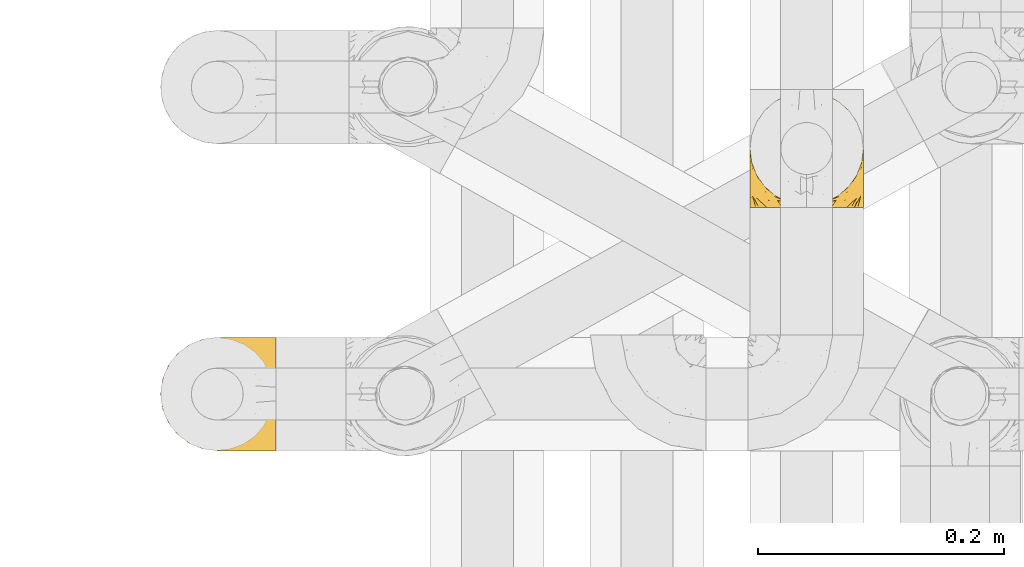
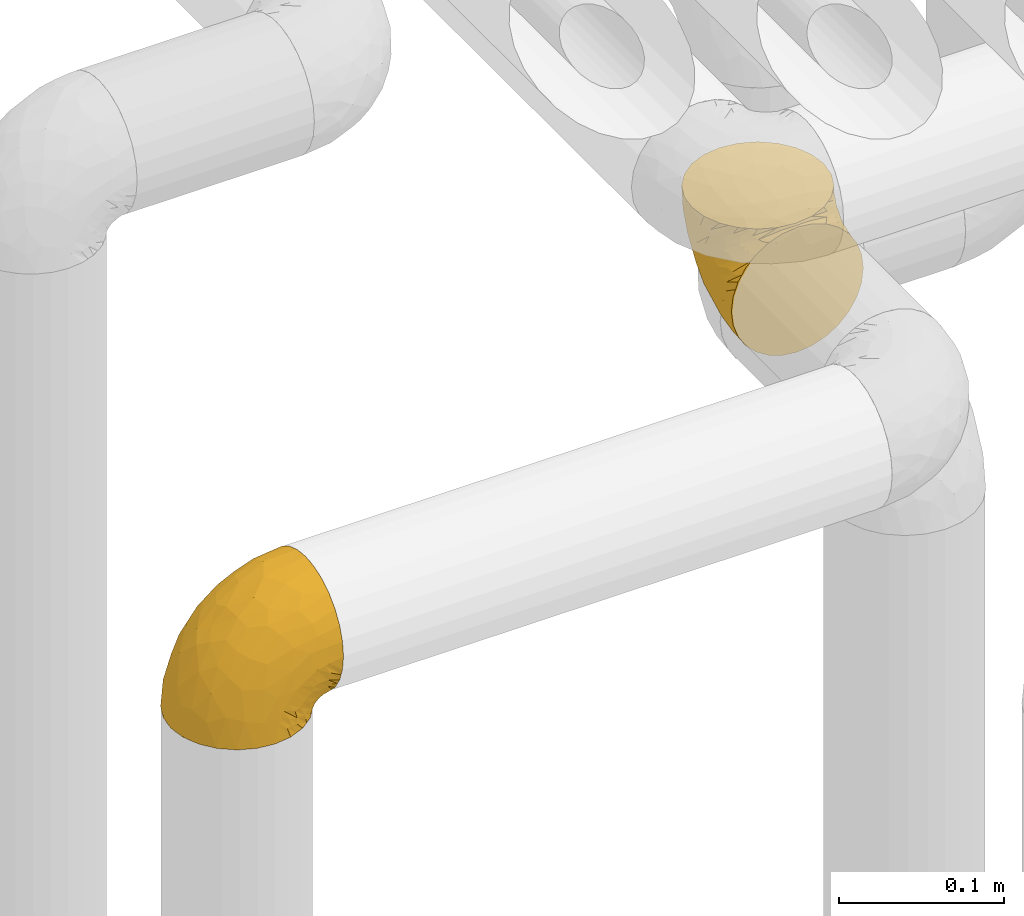
# One storey, part 172 of 827: 2 coverings.
"""IFC2X3 building model written with IfcOpenShell, lengths in millimetres."""

from ifc_helpers import new_model, entity, si_unit, converted_unit, derived_unit, direction, frame, origin, place, context, subcontext, project, spatial, faceted_brep, element, save


model = new_model("IFC2X3")

# Units and contexts
model_context = context("Model", 3, precision=0.01, world=origin(), true_north=direction((6.12303176911189e-17, 1.0)))
body_context = subcontext(model_context, "Body", "Model", "MODEL_VIEW")
ifc_project = project(units=[si_unit("LENGTHUNIT", "METRE", prefix="MILLI"), si_unit("AREAUNIT", "SQUARE_METRE"), si_unit("VOLUMEUNIT", "CUBIC_METRE"), converted_unit("PLANEANGLEUNIT", "DEGREE", entity("IfcRatioMeasure", 0.0174532925199433), si_unit("PLANEANGLEUNIT", "RADIAN"), dimensions=[0, 0, 0, 0, 0, 0, 0]), si_unit("MASSUNIT", "GRAM", prefix="KILO"), derived_unit("MASSDENSITYUNIT", [(si_unit("MASSUNIT", "GRAM", prefix="KILO"), 1), (si_unit("LENGTHUNIT", "METRE"), -3)]), derived_unit("MOMENTOFINERTIAUNIT", [(si_unit("LENGTHUNIT", "METRE"), 4)]), si_unit("TIMEUNIT", "SECOND"), si_unit("FREQUENCYUNIT", "HERTZ"), si_unit("THERMODYNAMICTEMPERATUREUNIT", "DEGREE_CELSIUS"), derived_unit("THERMALTRANSMITTANCEUNIT", [(si_unit("MASSUNIT", "GRAM", prefix="KILO"), 1), (si_unit("THERMODYNAMICTEMPERATUREUNIT", "KELVIN"), -1), (si_unit("TIMEUNIT", "SECOND"), -3)]), derived_unit("VOLUMETRICFLOWRATEUNIT", [(si_unit("LENGTHUNIT", "METRE"), 3), (si_unit("TIMEUNIT", "SECOND"), -1)]), derived_unit("MASSFLOWRATEUNIT", [(si_unit("MASSUNIT", "GRAM", prefix="KILO"), 1), (si_unit("TIMEUNIT", "SECOND"), -1)]), derived_unit("ROTATIONALFREQUENCYUNIT", [(si_unit("TIMEUNIT", "SECOND"), -1)]), si_unit("ELECTRICCURRENTUNIT", "AMPERE"), si_unit("ELECTRICVOLTAGEUNIT", "VOLT"), si_unit("POWERUNIT", "WATT"), si_unit("FORCEUNIT", "NEWTON", prefix="KILO"), si_unit("ILLUMINANCEUNIT", "LUX"), si_unit("LUMINOUSFLUXUNIT", "LUMEN"), si_unit("LUMINOUSINTENSITYUNIT", "CANDELA"), derived_unit("USERDEFINED", [(si_unit("MASSUNIT", "GRAM", prefix="KILO"), -1), (si_unit("LENGTHUNIT", "METRE"), -2), (si_unit("TIMEUNIT", "SECOND"), 3), (si_unit("LUMINOUSFLUXUNIT", "LUMEN"), 1)]), derived_unit("LINEARVELOCITYUNIT", [(si_unit("LENGTHUNIT", "METRE"), 1), (si_unit("TIMEUNIT", "SECOND"), -1)]), si_unit("PRESSUREUNIT", "PASCAL"), derived_unit("USERDEFINED", [(si_unit("LENGTHUNIT", "METRE"), -2), (si_unit("MASSUNIT", "GRAM", prefix="KILO"), 1), (si_unit("TIMEUNIT", "SECOND"), -2)]), derived_unit("LINEARFORCEUNIT", [(si_unit("MASSUNIT", "GRAM", prefix="KILO"), 1), (si_unit("LENGTHUNIT", "METRE"), 1), (si_unit("TIMEUNIT", "SECOND"), -2), (si_unit("LENGTHUNIT", "METRE"), -1)]), derived_unit("PLANARFORCEUNIT", [(si_unit("MASSUNIT", "GRAM", prefix="KILO"), 1), (si_unit("LENGTHUNIT", "METRE"), 1), (si_unit("TIMEUNIT", "SECOND"), -2), (si_unit("LENGTHUNIT", "METRE"), -2)])], contexts=[model_context])

# Site, building, storey
site_placement = place(None, origin())
site = spatial("IfcSite", under=ifc_project, at=site_placement, CompositionType="ELEMENT")
building_placement = place(site_placement, origin())
building = spatial("IfcBuilding", under=site, at=building_placement, CompositionType="ELEMENT")
storey_placement = place(building_placement, frame((0.0, 0.0, 28200.0)))
storey = spatial("IfcBuildingStorey", under=building, at=storey_placement, Name="08", CompositionType="ELEMENT", Elevation=28200.0)

# Coverings
covering_1_placement = place(storey_placement, frame((35552.3, 12906.58, 2751.81)))
element("IfcCovering", 1, at=covering_1_placement, inside=storey, Name=":ADSK_", ObjectType=":ADSK_", PredefinedType="INSULATION", context=body_context, shape_type="Brep", body=[
    faceted_brep([(11.68, 1.6, 18.98), (19.0, 1.6, 11.67), (27.76, 1.6, 6.17), (37.52, 1.6, 2.75), (47.8, 1.6, 1.6), (58.08, 1.6, 2.75), (67.85, 1.6, 6.17), (76.61, 1.6, 11.68), (83.92, 1.6, 19.0), (89.42, 1.6, 27.76), (92.84, 1.6, 37.52), (94.0, 1.6, 47.8), (93.53, 1.6, 51.94), (93.18, 1.6, 55.01), (92.84, 1.6, 58.08), (91.13, 1.6, 62.96), (89.42, 1.6, 67.85), (86.66, 1.6, 72.23), (83.91, 1.6, 76.61), (80.25, 1.6, 80.26), (76.59, 1.6, 83.92), (67.83, 1.6, 89.42), (62.95, 1.6, 91.13), (58.07, 1.6, 92.84), (47.8, 1.6, 94.0), (37.51, 1.6, 92.84), (32.63, 1.6, 91.13), (27.74, 1.6, 89.42), (18.98, 1.6, 83.91), (15.33, 1.6, 80.25), (11.67, 1.6, 76.59), (8.92, 1.6, 72.21), (6.17, 1.6, 67.83), (4.46, 1.6, 62.95), (2.75, 1.6, 58.07), (2.41, 1.6, 55.0), (2.06, 1.6, 51.94), (1.6, 1.6, 47.8), (2.75, 1.6, 37.51), (6.17, 1.6, 27.74), (47.8, 3.4, 95.8), (59.75, 4.97, 95.8), (70.9, 9.58, 95.8), (75.68, 13.26, 95.8), (80.46, 16.93, 95.8), (84.13, 21.71, 95.8), (87.81, 26.5, 95.8), (90.11, 32.07, 95.8), (92.42, 37.64, 95.8), (92.9, 41.25, 95.8), (93.17, 43.34, 95.8), (93.45, 45.42, 95.8), (94.0, 49.6, 95.8), (92.42, 61.55, 95.8), (87.81, 72.7, 95.8), (80.46, 82.26, 95.8), (70.9, 89.61, 95.8), (59.75, 94.22, 95.8), (47.8, 95.8, 95.8), (35.84, 94.22, 95.8), (24.7, 89.61, 95.8), (15.13, 82.26, 95.8), (7.78, 72.7, 95.8), (3.17, 61.55, 95.8), (1.6, 49.6, 95.8), (2.14, 45.42, 95.8), (2.69, 41.25, 95.8), (3.17, 37.64, 95.8), (5.48, 32.07, 95.8), (7.78, 26.5, 95.8), (11.46, 21.71, 95.8), (15.13, 16.93, 95.8), (19.91, 13.26, 95.8), (24.7, 9.58, 95.8), (35.84, 4.97, 95.8), (23.61, 81.55, 60.58), (31.99, 90.4, 74.11), (35.87, 83.0, 51.59), (47.8, 91.18, 66.69), (40.43, 93.13, 76.19), (47.8, 94.0, 84.43), (31.83, 66.19, 31.2), (23.37, 70.92, 42.88), (21.41, 85.95, 79.41), (3.07, 49.74, 60.7), (1.6, 35.54, 61.85), (1.6, 38.14, 65.75), (1.6, 40.74, 69.64), (1.6, 43.34, 73.53), (1.6, 45.94, 77.43), (13.45, 77.59, 74.59), (15.25, 71.17, 54.72), (8.07, 65.81, 64.18), (16.0, 59.03, 37.94), (17.34, 45.85, 25.89), (10.58, 45.79, 34.73), (5.34, 41.42, 42.89), (2.39, 34.51, 49.83), (8.36, 56.04, 48.58), (10.04, 15.15, 22.41), (2.59, 56.51, 78.69), (6.28, 68.39, 81.64), (34.28, 23.33, 6.22), (38.73, 42.86, 12.11), (27.25, 39.42, 14.81), (29.88, 53.58, 21.61), (38.6, 59.17, 22.41), (23.44, 59.06, 30.12), (25.25, 22.63, 10.01), (17.23, 20.55, 15.36), (47.8, 12.96, 3.39), (47.8, 56.96, 19.59), (47.8, 67.38, 30.01), (2.53, 18.72, 41.19), (1.6, 5.33, 48.54), (1.6, 9.07, 49.28), (1.6, 11.79, 49.82), (1.6, 14.51, 50.37), (1.6, 17.24, 50.91), (1.6, 19.96, 51.45), (5.71, 21.03, 31.61), (1.6, 46.48, 80.15), (1.6, 47.03, 82.88), (1.6, 47.57, 85.6), (1.6, 48.11, 88.32), (1.6, 48.48, 90.19), (1.6, 48.85, 92.06), (47.8, 30.7, 6.21), (1.6, 23.86, 54.05), (1.6, 27.75, 56.65), (1.6, 31.64, 59.25), (11.89, 31.26, 24.66), (47.8, 77.8, 40.43), (39.69, 72.75, 35.17), (47.8, 43.83, 12.9), (47.8, 84.49, 53.56), (13.84, 14.58, 85.34), (9.16, 16.17, 78.44), (15.79, 10.82, 84.37), (25.75, 4.64, 89.05), (16.09, 7.71, 82.76), (7.51, 25.13, 86.31), (3.99, 32.66, 83.73), (2.66, 34.94, 77.31), (3.16, 36.76, 87.78), (2.35, 40.48, 87.91), (2.23, 39.25, 81.29), (38.35, 3.69, 93.97), (6.18, 13.99, 70.76), (2.7, 21.85, 63.67), (2.93, 17.93, 62.62), (16.01, 15.11, 90.64), (9.08, 21.14, 84.08), (11.68, 7.21, 77.45), (6.83, 9.47, 70.34), (21.65, 10.45, 91.35), (4.65, 32.27, 88.72), (3.65, 25.68, 71.28), (3.61, 22.18, 68.09), (12.8, 18.79, 91.07), (2.43, 10.12, 57.47), (3.7, 11.29, 62.99), (47.8, 2.87, 94.52), (3.37, 31.16, 76.47), (9.3, 12.7, 76.28), (7.03, 6.31, 69.96), (7.87, 25.62, 89.86), (7.26, 21.18, 78.94), (3.41, 28.81, 73.51), (23.81, 7.45, 89.62), (86.5, 21.14, 84.09), (88.08, 25.13, 86.3), (82.79, 18.79, 91.06), (94.0, 48.85, 92.06), (94.0, 47.03, 82.88), (94.0, 47.57, 85.6), (94.0, 48.11, 88.32), (57.24, 3.69, 93.97), (71.76, 7.44, 89.63), (94.0, 14.51, 50.37), (94.0, 11.79, 49.82), (94.0, 5.33, 48.54), (94.0, 9.07, 49.28), (79.49, 7.71, 82.77), (88.75, 9.47, 70.36), (92.93, 34.94, 77.31), (92.22, 31.16, 76.47), (94.0, 40.74, 69.64), (94.0, 38.14, 65.75), (92.43, 36.76, 87.78), (93.24, 40.48, 87.91), (69.82, 4.63, 89.06), (79.57, 15.11, 90.65), (81.74, 14.58, 85.35), (94.0, 43.34, 73.53), (94.0, 45.94, 77.43), (93.36, 39.25, 81.29), (83.9, 7.21, 77.46), (86.28, 12.69, 76.29), (93.16, 10.14, 57.47), (92.88, 21.81, 63.71), (91.98, 22.19, 68.11), (89.41, 14.0, 70.77), (91.93, 25.69, 71.31), (86.42, 16.17, 78.46), (88.82, 6.66, 69.52), (92.66, 17.92, 62.64), (73.93, 10.45, 91.35), (94.0, 31.64, 59.25), (79.5, 10.64, 84.6), (91.89, 11.31, 62.98), (94.0, 19.96, 51.45), (94.0, 23.86, 54.05), (94.0, 27.75, 56.65), (91.6, 32.66, 83.73), (94.0, 46.48, 80.15), (90.94, 32.27, 88.72), (94.0, 35.54, 61.85), (92.16, 28.77, 73.56), (88.32, 21.17, 78.96), (86.13, 23.36, 91.36), (94.0, 17.24, 50.91), (93.2, 47.58, 62.87), (55.16, 93.13, 76.19), (82.02, 77.44, 73.57), (84.29, 66.78, 56.07), (76.94, 71.68, 49.77), (68.33, 74.96, 44.73), (71.98, 81.55, 60.58), (92.52, 36.7, 47.64), (92.9, 56.9, 78.32), (59.72, 83.0, 51.59), (63.6, 90.4, 74.11), (88.89, 67.83, 76.04), (74.18, 85.95, 79.41), (68.35, 39.41, 14.82), (61.33, 23.33, 6.22), (56.86, 42.87, 12.12), (68.62, 53.92, 23.51), (63.76, 66.19, 31.2), (72.19, 64.12, 34.96), (88.69, 33.13, 33.86), (92.19, 23.1, 38.94), (89.75, 16.98, 30.23), (59.86, 55.72, 20.67), (55.9, 72.75, 35.17), (77.99, 23.77, 15.85), (85.21, 18.41, 22.59), (74.99, 43.7, 21.56), (90.23, 54.53, 55.94), (70.75, 17.73, 9.19), (81.72, 38.98, 25.79), (86.53, 50.28, 41.16), (79.6, 59.02, 37.95)], [[[0, 1, 2, 3, 4, 5, 6, 7, 8, 9, 10, 11, 12, 13, 14, 15, 16, 17, 18, 19, 20, 21, 22, 23, 24, 25, 26, 27, 28, 29, 30, 31, 32, 33, 34, 35, 36, 37, 38, 39]], [[40, 41, 42, 43, 44, 45, 46, 47, 48, 49, 50, 51, 52, 53, 54, 55, 56, 57, 58, 59, 60, 61, 62, 63, 64, 65, 66, 67, 68, 69, 70, 71, 72, 73, 74]], [[75, 76, 77]], [[78, 79, 80]], [[77, 81, 82]], [[76, 75, 83]], [[84, 85, 86, 87, 88, 89]], [[90, 91, 92]], [[76, 60, 59]], [[93, 94, 95]], [[90, 62, 61]], [[83, 61, 60]], [[96, 97, 84]], [[98, 93, 95]], [[0, 39, 99]], [[100, 84, 89]], [[62, 101, 63]], [[2, 102, 3]], [[92, 84, 100]], [[103, 102, 104]], [[103, 105, 106]], [[93, 107, 94]], [[1, 108, 2]], [[92, 101, 90]], [[108, 1, 109]], [[102, 110, 3]], [[93, 82, 107]], [[102, 108, 104]], [[111, 106, 112]], [[109, 0, 99]], [[113, 37, 114, 115, 116, 117, 118, 119]], [[120, 38, 113]], [[100, 89, 121, 122, 123, 124, 125, 126, 64]], [[127, 102, 103]], [[97, 119, 128, 129, 130, 85]], [[99, 120, 131]], [[132, 133, 77]], [[59, 80, 79]], [[1, 0, 109]], [[98, 84, 92]], [[94, 109, 131]], [[120, 39, 38]], [[93, 91, 82]], [[104, 94, 105]], [[97, 113, 119]], [[95, 120, 96]], [[83, 90, 61]], [[91, 93, 98]], [[64, 63, 100]], [[100, 63, 101]], [[77, 76, 79]], [[133, 106, 81]], [[84, 97, 85]], [[113, 96, 120]], [[113, 97, 96]], [[37, 113, 38]], [[110, 102, 127]], [[110, 4, 3]], [[103, 111, 134, 127]], [[90, 75, 91]], [[82, 81, 107]], [[91, 75, 82]], [[77, 82, 75]], [[76, 83, 60]], [[90, 83, 75]], [[105, 107, 81]], [[94, 131, 95]], [[105, 94, 107]], [[109, 94, 104]], [[120, 95, 131]], [[98, 95, 96]], [[84, 98, 96]], [[98, 92, 91]], [[106, 105, 81]], [[103, 104, 105]], [[133, 132, 112]], [[103, 106, 111]], [[77, 78, 135, 132]], [[106, 133, 112]], [[77, 133, 81]], [[120, 99, 39]], [[109, 99, 131]], [[59, 58, 80]], [[59, 79, 76]], [[90, 101, 62]], [[100, 101, 92]], [[2, 108, 102]], [[109, 104, 108]], [[78, 77, 79]], [[136, 137, 138]], [[27, 139, 140]], [[141, 142, 143]], [[144, 145, 121]], [[146, 89, 88]], [[147, 139, 25]], [[148, 149, 150]], [[136, 151, 152]], [[147, 40, 74]], [[24, 147, 25]], [[153, 148, 154]], [[33, 116, 34]], [[73, 151, 155]], [[114, 37, 36, 35, 34, 116, 115]], [[146, 156, 144]], [[157, 85, 130]], [[158, 149, 148]], [[151, 159, 152]], [[117, 33, 160]], [[29, 153, 154]], [[155, 74, 73]], [[161, 128, 119]], [[66, 65, 64, 126, 125, 124, 123, 122, 67]], [[162, 147, 24]], [[27, 140, 28]], [[149, 129, 150]], [[139, 27, 26, 25]], [[68, 144, 69]], [[129, 128, 150]], [[163, 87, 86]], [[130, 129, 149]], [[122, 145, 67]], [[153, 164, 148]], [[161, 119, 160]], [[165, 30, 154]], [[150, 154, 148]], [[128, 161, 150]], [[30, 165, 31]], [[145, 144, 68]], [[89, 146, 144]], [[87, 163, 143]], [[166, 156, 142]], [[88, 87, 143]], [[161, 154, 150]], [[154, 30, 29]], [[29, 28, 153]], [[28, 140, 153]], [[164, 153, 140]], [[140, 137, 164]], [[158, 148, 164]], [[157, 130, 158]], [[164, 137, 158]], [[158, 137, 157]], [[167, 137, 136]], [[168, 85, 157]], [[152, 168, 167]], [[167, 168, 157]], [[163, 152, 141]], [[151, 73, 72]], [[159, 72, 71]], [[88, 142, 146]], [[144, 156, 69]], [[146, 142, 156]], [[70, 166, 71]], [[142, 141, 166]], [[70, 69, 156]], [[141, 159, 71]], [[167, 136, 152]], [[138, 137, 140]], [[155, 136, 169]], [[136, 155, 151]], [[74, 155, 169]], [[152, 159, 141]], [[151, 72, 159]], [[168, 152, 163]], [[137, 167, 157]], [[163, 86, 168]], [[85, 168, 86]], [[116, 33, 117]], [[130, 149, 158]], [[67, 145, 68]], [[121, 89, 144]], [[145, 122, 121]], [[40, 147, 162]], [[169, 147, 74]], [[160, 33, 32]], [[161, 160, 32]], [[160, 119, 118, 117]], [[139, 147, 169]], [[139, 169, 138]], [[161, 32, 31]], [[141, 143, 163]], [[88, 143, 142]], [[71, 166, 141]], [[156, 166, 70]], [[139, 138, 140]], [[169, 136, 138]], [[154, 161, 165]], [[161, 31, 165]], [[170, 171, 172]], [[173, 52, 51, 50, 49, 48, 174, 175, 176]], [[177, 178, 41]], [[179, 15, 180]], [[12, 11, 181, 182, 180, 14, 13]], [[183, 21, 20]], [[19, 18, 184]], [[185, 186, 187]], [[186, 188, 187]], [[43, 172, 44]], [[189, 190, 47]], [[23, 22, 21, 191]], [[170, 192, 193]], [[40, 162, 177]], [[194, 195, 196]], [[24, 23, 177]], [[197, 198, 183]], [[199, 15, 179]], [[47, 46, 189]], [[200, 201, 202]], [[201, 203, 204]], [[205, 206, 184]], [[207, 41, 178]], [[16, 15, 199]], [[14, 180, 15]], [[202, 201, 198]], [[208, 201, 200]], [[162, 24, 177]], [[48, 47, 190]], [[196, 195, 189]], [[197, 184, 202]], [[204, 193, 209]], [[210, 211, 212]], [[206, 212, 213]], [[205, 17, 210]], [[184, 206, 202]], [[210, 212, 206]], [[185, 194, 214]], [[189, 215, 190]], [[216, 45, 214]], [[186, 171, 170]], [[189, 216, 196]], [[197, 20, 19]], [[194, 185, 187]], [[197, 183, 20]], [[184, 197, 19]], [[197, 202, 198]], [[206, 200, 202]], [[204, 183, 198]], [[201, 208, 203]], [[203, 208, 217]], [[204, 198, 201]], [[217, 188, 218]], [[193, 219, 170]], [[171, 186, 185]], [[170, 218, 186]], [[170, 219, 218]], [[42, 207, 192]], [[171, 220, 172]], [[216, 189, 46]], [[214, 194, 196]], [[44, 220, 45]], [[214, 196, 216]], [[216, 46, 45]], [[214, 45, 220]], [[192, 43, 42]], [[204, 203, 219]], [[207, 193, 192]], [[209, 193, 178]], [[41, 207, 42]], [[193, 207, 178]], [[43, 192, 172]], [[170, 172, 192]], [[204, 219, 193]], [[219, 203, 218]], [[217, 218, 203]], [[188, 186, 218]], [[206, 213, 200]], [[208, 200, 213]], [[199, 210, 16]], [[215, 189, 195]], [[215, 174, 190]], [[174, 48, 190]], [[199, 179, 221, 211]], [[210, 199, 211]], [[23, 191, 177]], [[40, 177, 41]], [[183, 209, 191]], [[183, 191, 21]], [[191, 178, 177]], [[205, 18, 17]], [[17, 16, 210]], [[171, 185, 214]], [[172, 220, 44]], [[214, 220, 171]], [[191, 209, 178]], [[204, 209, 183]], [[206, 205, 210]], [[18, 205, 184]], [[222, 195, 194, 187, 188, 217]], [[57, 223, 80]], [[224, 225, 226]], [[226, 227, 228]], [[229, 217, 208, 213, 212, 211]], [[230, 52, 173, 176, 175, 174, 215, 195]], [[231, 232, 228]], [[231, 78, 223]], [[223, 57, 232]], [[224, 233, 225]], [[233, 54, 53]], [[234, 232, 56]], [[56, 55, 234]], [[234, 224, 228]], [[235, 236, 237]], [[224, 55, 54]], [[238, 239, 240]], [[52, 230, 53]], [[241, 242, 243]], [[239, 244, 245]], [[11, 10, 242]], [[236, 6, 5]], [[7, 246, 8]], [[8, 247, 9]], [[238, 248, 235]], [[222, 229, 249]], [[242, 211, 221, 179, 180, 182, 181, 11]], [[233, 53, 230]], [[111, 112, 244]], [[250, 6, 236]], [[247, 251, 241]], [[6, 250, 7]], [[127, 236, 110]], [[249, 229, 252]], [[247, 8, 246]], [[235, 246, 250]], [[236, 5, 110]], [[235, 244, 238]], [[237, 236, 127]], [[243, 9, 247]], [[252, 229, 241]], [[56, 232, 57]], [[222, 230, 195]], [[225, 249, 252]], [[249, 233, 230]], [[54, 233, 224]], [[231, 228, 227]], [[245, 132, 231]], [[249, 225, 233]], [[226, 225, 253]], [[235, 250, 236]], [[246, 7, 250]], [[251, 247, 246]], [[243, 247, 241]], [[248, 246, 235]], [[252, 251, 253]], [[229, 222, 217]], [[230, 222, 249]], [[5, 4, 110]], [[237, 127, 134, 111]], [[238, 244, 239]], [[224, 234, 55]], [[232, 234, 228]], [[242, 241, 229]], [[10, 9, 243]], [[211, 242, 229]], [[10, 243, 242]], [[80, 223, 78]], [[80, 58, 57]], [[231, 223, 232]], [[227, 240, 239]], [[224, 226, 228]], [[240, 226, 253]], [[227, 239, 245]], [[226, 240, 227]], [[251, 248, 253]], [[240, 253, 248]], [[244, 235, 237]], [[237, 111, 244]], [[132, 245, 112]], [[112, 245, 244]], [[135, 78, 231, 132]], [[227, 245, 231]], [[248, 238, 240]], [[246, 248, 251]], [[251, 252, 241]], [[225, 252, 253]]]),
])
covering_2_placement = place(storey_placement, frame((35072.24, 12708.4, 2750.01)))
element("IfcCovering", 2, at=covering_2_placement, inside=storey, Name=":ADSK_", ObjectType=":ADSK_", PredefinedType="INSULATION", context=body_context, shape_type="Brep", body=[
    faceted_brep([(95.8, 94.0, 49.6), (95.8, 92.84, 59.88), (95.8, 89.42, 69.65), (95.8, 83.91, 78.41), (95.8, 76.59, 85.72), (95.8, 67.83, 91.22), (95.8, 58.07, 94.64), (95.8, 47.8, 95.8), (95.79, 37.51, 94.64), (95.79, 27.74, 91.22), (95.79, 18.98, 85.71), (95.79, 11.67, 78.39), (95.79, 6.17, 69.63), (95.79, 2.75, 59.87), (95.79, 1.6, 49.6), (95.79, 2.06, 45.45), (95.79, 2.41, 42.38), (95.79, 2.75, 39.31), (95.79, 4.46, 34.43), (95.79, 6.17, 29.54), (95.79, 8.93, 25.16), (95.79, 11.68, 20.78), (95.79, 15.34, 17.13), (95.79, 19.0, 13.47), (95.79, 27.76, 7.97), (95.79, 32.64, 6.26), (95.79, 37.52, 4.55), (95.8, 47.8, 3.4), (95.8, 58.08, 4.55), (95.8, 62.96, 6.26), (95.8, 67.85, 7.97), (95.8, 76.61, 13.48), (95.8, 80.26, 17.14), (95.8, 83.92, 20.8), (95.8, 86.67, 25.18), (95.8, 89.42, 29.56), (95.8, 91.13, 34.44), (95.8, 92.84, 39.32), (95.8, 93.18, 42.39), (95.8, 93.53, 45.45), (94.0, 47.8, 1.6), (92.42, 35.84, 1.6), (87.8, 24.7, 1.6), (84.13, 19.91, 1.6), (80.46, 15.13, 1.6), (75.68, 11.46, 1.6), (70.89, 7.79, 1.6), (65.32, 5.48, 1.6), (59.75, 3.17, 1.6), (56.14, 2.7, 1.6), (54.05, 2.42, 1.6), (51.97, 2.15, 1.6), (47.79, 1.6, 1.6), (35.83, 3.17, 1.6), (24.69, 7.79, 1.6), (15.12, 15.13, 1.6), (7.78, 24.7, 1.6), (3.17, 35.84, 1.6), (1.6, 47.8, 1.6), (3.17, 59.76, 1.6), (7.79, 70.9, 1.6), (15.13, 80.47, 1.6), (24.7, 87.81, 1.6), (35.84, 92.43, 1.6), (47.8, 94.0, 1.6), (51.97, 93.45, 1.6), (56.14, 92.9, 1.6), (59.76, 92.42, 1.6), (65.33, 90.12, 1.6), (70.9, 87.81, 1.6), (75.68, 84.14, 1.6), (80.47, 80.46, 1.6), (84.14, 75.68, 1.6), (87.81, 70.9, 1.6), (92.42, 59.75, 1.6), (15.84, 71.99, 36.81), (6.99, 63.61, 23.28), (14.39, 59.73, 45.8), (6.21, 47.8, 30.7), (4.26, 55.17, 21.2), (3.39, 47.8, 12.96), (31.2, 63.76, 66.19), (26.47, 72.23, 54.51), (11.45, 74.18, 17.98), (47.66, 92.53, 36.69), (61.86, 94.0, 35.54), (59.26, 94.0, 31.64), (56.65, 94.0, 27.75), (54.05, 94.0, 23.86), (51.45, 94.0, 19.96), (19.8, 82.15, 22.8), (26.22, 80.34, 42.67), (31.58, 87.53, 33.21), (38.36, 79.59, 59.45), (51.54, 78.26, 71.5), (51.6, 85.01, 62.66), (55.97, 90.25, 54.5), (62.88, 93.2, 47.57), (41.35, 87.23, 48.81), (82.25, 85.55, 74.98), (40.88, 93.01, 18.7), (29.01, 89.31, 15.75), (74.06, 61.32, 91.17), (54.53, 56.86, 85.28), (57.98, 68.34, 82.58), (43.81, 65.71, 75.78), (38.22, 57.0, 74.98), (38.34, 72.15, 67.27), (74.76, 70.34, 87.38), (76.85, 78.36, 82.04), (84.43, 47.8, 94.0), (40.43, 47.8, 77.8), (30.01, 47.8, 67.38), (78.68, 93.06, 56.2), (92.06, 94.0, 48.85), (88.33, 94.0, 48.11), (85.6, 94.0, 47.57), (82.88, 94.0, 47.03), (80.15, 94.0, 46.48), (77.43, 94.0, 45.94), (76.37, 89.88, 65.78), (50.91, 94.0, 17.24), (50.37, 94.0, 14.51), (49.83, 94.0, 11.79), (49.28, 94.0, 9.07), (48.91, 94.0, 7.2), (48.54, 94.0, 5.33), (66.69, 47.8, 91.18), (73.54, 94.0, 43.34), (69.64, 94.0, 40.74), (65.75, 94.0, 38.14), (66.13, 83.7, 72.73), (19.59, 47.8, 56.96), (24.64, 55.91, 62.23), (53.56, 47.8, 84.49), (12.9, 47.8, 43.83), (82.81, 81.75, 12.05), (81.22, 86.43, 18.95), (86.57, 79.8, 13.02), (92.75, 69.84, 8.34), (89.69, 79.5, 14.63), (72.27, 88.08, 11.09), (64.73, 91.6, 13.66), (62.46, 92.93, 20.08), (60.64, 92.43, 9.61), (56.91, 93.24, 9.48), (58.15, 93.36, 16.1), (93.7, 57.25, 3.42), (83.4, 89.41, 26.63), (75.54, 92.9, 33.72), (79.46, 92.66, 34.77), (82.28, 79.58, 6.75), (76.25, 86.51, 13.31), (90.18, 83.91, 19.94), (84.7, 86.29, 21.11), (86.94, 73.94, 6.04), (65.12, 90.94, 8.67), (71.71, 91.94, 26.11), (75.21, 91.98, 29.3), (78.6, 82.79, 6.32), (87.28, 93.16, 39.92), (87.92, 88.76, 27.05), (86.1, 91.89, 34.4), (94.52, 47.8, 2.87), (66.23, 92.22, 20.92), (91.09, 88.56, 27.43), (71.77, 87.72, 7.54), (76.22, 88.33, 18.45), (68.59, 92.18, 23.88), (89.94, 71.78, 7.77), (76.22, 7.27, 18.43), (81.22, 9.17, 18.93), (71.7, 3.66, 26.08), (49.28, 1.6, 9.07), (48.54, 1.6, 5.33), (50.36, 1.6, 14.51), (49.82, 1.6, 11.79), (93.7, 38.35, 3.42), (89.95, 23.84, 7.76), (82.87, 1.6, 47.03), (85.6, 1.6, 47.57), (92.06, 1.6, 48.85), (88.32, 1.6, 48.11), (89.68, 16.1, 14.62), (87.92, 6.84, 27.03), (62.45, 2.67, 20.08), (66.23, 3.37, 20.92), (56.65, 1.6, 27.75), (59.25, 1.6, 31.64), (78.6, 12.8, 6.33), (60.63, 3.17, 9.61), (56.91, 2.35, 9.48), (92.76, 25.77, 8.33), (76.25, 9.09, 13.3), (82.28, 16.02, 6.74), (82.81, 13.85, 12.04), (54.05, 1.6, 23.86), (51.45, 1.6, 19.96), (58.14, 2.24, 16.1), (90.18, 11.69, 19.93), (84.69, 9.31, 21.1), (87.25, 2.43, 39.92), (75.57, 2.71, 33.68), (75.2, 3.61, 29.28), (83.39, 6.19, 26.62), (90.73, 6.77, 27.87), (79.47, 2.94, 34.75), (86.94, 21.66, 6.04), (65.74, 1.6, 38.14), (86.75, 16.09, 12.79), (86.08, 3.7, 34.41), (77.42, 1.6, 45.94), (73.53, 1.6, 43.34), (69.64, 1.6, 40.74), (64.73, 3.99, 13.66), (50.9, 1.6, 17.24), (65.12, 4.65, 8.67), (72.26, 7.52, 11.09), (61.85, 1.6, 35.54), (68.61, 3.43, 23.83), (74.03, 9.47, 6.03), (80.15, 1.6, 46.48), (49.81, 2.4, 34.52), (4.26, 40.43, 21.2), (19.95, 13.57, 23.82), (30.61, 11.31, 41.32), (25.71, 18.66, 47.62), (22.43, 27.26, 52.66), (15.84, 23.61, 36.81), (60.69, 3.07, 49.75), (40.49, 2.69, 19.07), (14.39, 35.87, 45.8), (6.99, 31.99, 23.28), (29.56, 6.71, 21.35), (11.44, 21.42, 17.98), (57.98, 27.24, 82.57), (74.06, 34.27, 91.17), (54.52, 38.73, 85.27), (43.47, 26.97, 73.89), (31.2, 31.83, 66.19), (33.27, 23.41, 62.43), (64.26, 6.91, 63.53), (74.29, 3.4, 58.45), (80.4, 5.84, 67.16), (41.67, 35.73, 76.72), (24.64, 39.69, 62.22), (73.62, 17.6, 81.54), (78.98, 10.39, 74.8), (53.69, 20.6, 75.83), (42.86, 5.36, 41.45), (79.66, 24.84, 88.2), (58.41, 13.87, 71.6), (47.11, 9.06, 56.23), (38.37, 16.0, 59.44)], [[[0, 1, 2, 3, 4, 5, 6, 7, 8, 9, 10, 11, 12, 13, 14, 15, 16, 17, 18, 19, 20, 21, 22, 23, 24, 25, 26, 27, 28, 29, 30, 31, 32, 33, 34, 35, 36, 37, 38, 39]], [[40, 41, 42, 43, 44, 45, 46, 47, 48, 49, 50, 51, 52, 53, 54, 55, 56, 57, 58, 59, 60, 61, 62, 63, 64, 65, 66, 67, 68, 69, 70, 71, 72, 73, 74]], [[75, 76, 77]], [[78, 79, 80]], [[77, 81, 82]], [[76, 75, 83]], [[84, 85, 86, 87, 88, 89]], [[90, 91, 92]], [[76, 60, 59]], [[93, 94, 95]], [[90, 62, 61]], [[83, 61, 60]], [[96, 97, 84]], [[98, 93, 95]], [[3, 2, 99]], [[100, 84, 89]], [[62, 101, 63]], [[5, 102, 6]], [[92, 84, 100]], [[103, 102, 104]], [[103, 105, 106]], [[93, 107, 94]], [[4, 108, 5]], [[92, 101, 90]], [[108, 4, 109]], [[102, 110, 6]], [[93, 82, 107]], [[102, 108, 104]], [[111, 106, 112]], [[109, 3, 99]], [[113, 0, 114, 115, 116, 117, 118, 119]], [[120, 1, 113]], [[100, 89, 121, 122, 123, 124, 125, 126, 64]], [[127, 102, 103]], [[97, 119, 128, 129, 130, 85]], [[99, 120, 131]], [[132, 133, 77]], [[59, 80, 79]], [[4, 3, 109]], [[98, 84, 92]], [[94, 109, 131]], [[120, 2, 1]], [[93, 91, 82]], [[104, 94, 105]], [[97, 113, 119]], [[95, 120, 96]], [[83, 90, 61]], [[91, 93, 98]], [[64, 63, 100]], [[100, 63, 101]], [[77, 76, 79]], [[133, 106, 81]], [[84, 97, 85]], [[113, 96, 120]], [[113, 97, 96]], [[0, 113, 1]], [[110, 102, 127]], [[110, 7, 6]], [[103, 111, 134, 127]], [[90, 75, 91]], [[82, 81, 107]], [[91, 75, 82]], [[77, 82, 75]], [[76, 83, 60]], [[90, 83, 75]], [[105, 107, 81]], [[94, 131, 95]], [[105, 94, 107]], [[109, 94, 104]], [[120, 95, 131]], [[98, 95, 96]], [[84, 98, 96]], [[98, 92, 91]], [[106, 105, 81]], [[103, 104, 105]], [[112, 106, 133]], [[103, 106, 111]], [[112, 133, 132]], [[81, 77, 133]], [[77, 78, 135, 132]], [[120, 99, 2]], [[109, 99, 131]], [[59, 58, 80]], [[59, 79, 76]], [[90, 101, 62]], [[100, 101, 92]], [[5, 108, 102]], [[109, 104, 108]], [[78, 77, 79]], [[136, 137, 138]], [[30, 139, 140]], [[141, 142, 143]], [[144, 145, 121]], [[146, 89, 88]], [[147, 139, 28]], [[148, 149, 150]], [[136, 151, 152]], [[147, 40, 74]], [[27, 147, 28]], [[153, 140, 154]], [[36, 116, 37]], [[73, 151, 155]], [[114, 0, 39, 38, 37, 116, 115]], [[146, 156, 144]], [[157, 85, 130]], [[158, 149, 148]], [[151, 159, 152]], [[117, 36, 160]], [[32, 153, 161]], [[155, 74, 73]], [[162, 128, 119]], [[66, 65, 64, 126, 125, 124, 123, 122, 67]], [[163, 147, 27]], [[30, 140, 31]], [[149, 129, 150]], [[139, 30, 29, 28]], [[68, 144, 69]], [[129, 128, 150]], [[164, 87, 86]], [[130, 129, 149]], [[122, 145, 67]], [[153, 154, 148]], [[162, 119, 160]], [[165, 33, 161]], [[150, 161, 148]], [[128, 162, 150]], [[33, 165, 34]], [[145, 144, 68]], [[89, 146, 144]], [[87, 164, 143]], [[166, 156, 142]], [[88, 87, 143]], [[162, 161, 150]], [[161, 33, 32]], [[161, 153, 148]], [[31, 140, 153]], [[32, 31, 153]], [[140, 137, 154]], [[158, 148, 154]], [[157, 130, 158]], [[154, 137, 158]], [[158, 137, 157]], [[167, 137, 136]], [[168, 85, 157]], [[152, 168, 167]], [[167, 168, 157]], [[164, 152, 141]], [[151, 73, 72]], [[159, 72, 71]], [[88, 142, 146]], [[144, 156, 69]], [[146, 142, 156]], [[70, 166, 71]], [[142, 141, 166]], [[70, 69, 156]], [[141, 159, 71]], [[167, 136, 152]], [[138, 137, 140]], [[155, 136, 169]], [[136, 155, 151]], [[74, 155, 169]], [[152, 159, 141]], [[151, 72, 159]], [[168, 152, 164]], [[137, 167, 157]], [[164, 86, 168]], [[85, 168, 86]], [[116, 36, 117]], [[130, 149, 158]], [[67, 145, 68]], [[121, 89, 144]], [[145, 122, 121]], [[40, 147, 163]], [[169, 147, 74]], [[160, 36, 35]], [[162, 160, 35]], [[160, 119, 118, 117]], [[139, 147, 169]], [[139, 169, 138]], [[162, 35, 34]], [[141, 143, 164]], [[88, 143, 142]], [[71, 166, 141]], [[156, 166, 70]], [[139, 138, 140]], [[169, 136, 138]], [[161, 162, 165]], [[162, 34, 165]], [[170, 171, 172]], [[173, 174, 52, 51, 50, 49, 48, 175, 176]], [[177, 178, 41]], [[179, 18, 180]], [[15, 14, 181, 182, 180, 17, 16]], [[183, 24, 23]], [[22, 21, 184]], [[185, 186, 187]], [[186, 188, 187]], [[43, 189, 44]], [[190, 191, 47]], [[26, 25, 24, 192]], [[193, 194, 195]], [[40, 163, 177]], [[196, 197, 198]], [[27, 26, 177]], [[199, 200, 183]], [[201, 18, 179]], [[47, 46, 190]], [[202, 203, 204]], [[203, 172, 171]], [[205, 206, 184]], [[207, 41, 178]], [[19, 18, 201]], [[17, 180, 18]], [[204, 203, 200]], [[208, 203, 202]], [[163, 27, 177]], [[48, 47, 191]], [[198, 197, 190]], [[199, 184, 204]], [[171, 195, 209]], [[210, 211, 212]], [[206, 212, 213]], [[205, 20, 210]], [[184, 206, 204]], [[210, 212, 206]], [[185, 196, 214]], [[190, 215, 191]], [[216, 45, 214]], [[186, 217, 193]], [[190, 216, 198]], [[199, 23, 22]], [[196, 185, 187]], [[199, 183, 23]], [[184, 199, 22]], [[199, 204, 200]], [[206, 202, 204]], [[171, 183, 200]], [[203, 208, 172]], [[172, 208, 218]], [[171, 200, 203]], [[218, 188, 219]], [[195, 170, 193]], [[217, 186, 185]], [[193, 219, 186]], [[193, 170, 219]], [[207, 194, 42]], [[217, 220, 189]], [[216, 190, 46]], [[214, 196, 198]], [[44, 220, 45]], [[214, 198, 216]], [[216, 46, 45]], [[214, 45, 220]], [[42, 194, 43]], [[189, 193, 217]], [[207, 195, 194]], [[209, 195, 178]], [[41, 207, 42]], [[195, 207, 178]], [[43, 194, 189]], [[193, 189, 194]], [[171, 170, 195]], [[170, 172, 219]], [[218, 219, 172]], [[188, 186, 219]], [[206, 213, 202]], [[208, 202, 213]], [[201, 210, 19]], [[215, 190, 197]], [[215, 175, 191]], [[175, 48, 191]], [[201, 179, 221, 211]], [[210, 201, 211]], [[26, 192, 177]], [[40, 177, 41]], [[183, 209, 192]], [[183, 192, 24]], [[192, 178, 177]], [[205, 21, 20]], [[20, 19, 210]], [[217, 185, 214]], [[189, 220, 44]], [[214, 220, 217]], [[192, 209, 178]], [[171, 209, 183]], [[206, 205, 210]], [[21, 205, 184]], [[222, 197, 196, 187, 188, 218]], [[57, 223, 80]], [[224, 225, 226]], [[226, 227, 228]], [[229, 218, 208, 213, 212, 211]], [[230, 52, 174, 173, 176, 175, 215, 197]], [[231, 232, 228]], [[231, 78, 223]], [[223, 57, 232]], [[224, 233, 225]], [[233, 54, 53]], [[234, 232, 56]], [[56, 55, 234]], [[234, 224, 228]], [[235, 236, 237]], [[224, 55, 54]], [[238, 239, 240]], [[52, 230, 53]], [[241, 242, 243]], [[239, 244, 245]], [[14, 13, 242]], [[236, 9, 8]], [[10, 246, 11]], [[11, 247, 12]], [[238, 248, 235]], [[222, 229, 249]], [[242, 211, 221, 179, 180, 182, 181, 14]], [[233, 53, 230]], [[111, 112, 244]], [[250, 9, 236]], [[247, 251, 241]], [[9, 250, 10]], [[127, 236, 110]], [[249, 229, 252]], [[247, 11, 246]], [[235, 246, 250]], [[236, 8, 110]], [[235, 244, 238]], [[237, 236, 127]], [[243, 12, 247]], [[252, 229, 241]], [[56, 232, 57]], [[222, 230, 197]], [[225, 249, 252]], [[249, 233, 230]], [[54, 233, 224]], [[231, 228, 227]], [[245, 132, 231]], [[249, 225, 233]], [[226, 225, 253]], [[235, 250, 236]], [[246, 10, 250]], [[251, 247, 246]], [[243, 247, 241]], [[248, 246, 235]], [[252, 251, 253]], [[229, 222, 218]], [[230, 222, 249]], [[8, 7, 110]], [[237, 127, 134, 111]], [[238, 244, 239]], [[224, 234, 55]], [[232, 234, 228]], [[242, 241, 229]], [[13, 12, 243]], [[211, 242, 229]], [[13, 243, 242]], [[80, 223, 78]], [[80, 58, 57]], [[231, 223, 232]], [[227, 240, 239]], [[224, 226, 228]], [[240, 226, 253]], [[227, 239, 245]], [[226, 240, 227]], [[251, 248, 253]], [[240, 253, 248]], [[244, 235, 237]], [[237, 111, 244]], [[132, 245, 112]], [[112, 245, 244]], [[135, 78, 231, 132]], [[227, 245, 231]], [[248, 238, 240]], [[246, 248, 251]], [[251, 252, 241]], [[225, 252, 253]]]),
])

save(model, "model.ifc")
